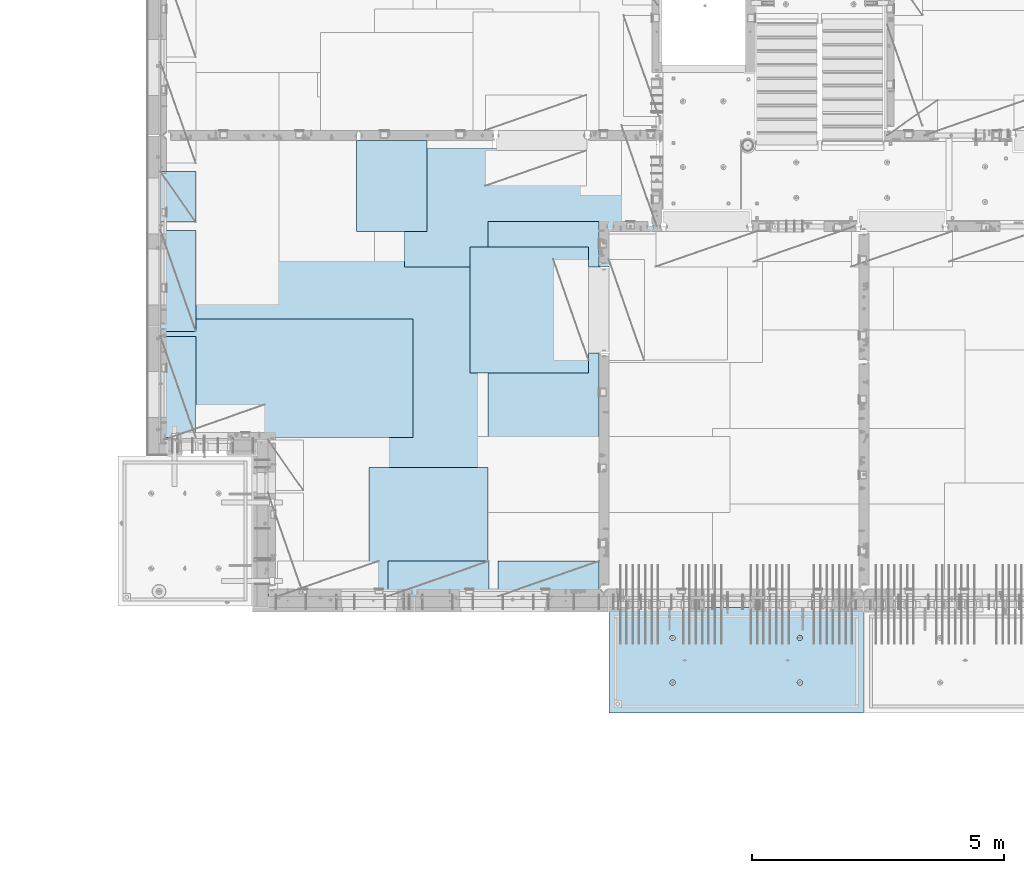
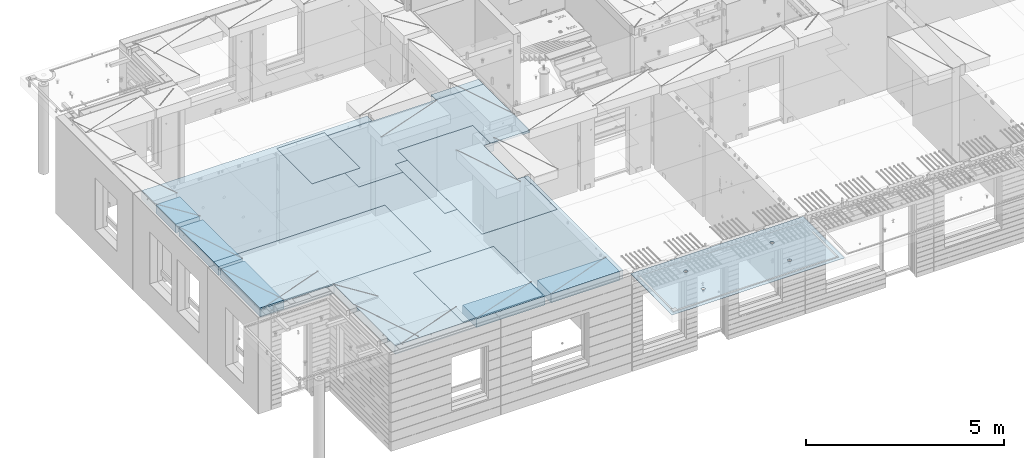
# One storey, part 200 of 349: 11 plates, 2 slabs, 11 elements without a shape of their own.
"""IFC2X3 building model written with IfcOpenShell, lengths in millimetres."""

from ifc_helpers import new_model, si_unit, frame, origin_with_axes, place, context, subcontext, project, spatial, faceted_brep, material, type_object, element, aggregate, save


model = new_model("IFC2X3")

# Units and contexts
model_context = context("Model", 3, precision=1e-05, world=origin_with_axes())
body_context = subcontext(model_context, "Body", "Model", "MODEL_VIEW")
ifc_project = project(units=[si_unit("LENGTHUNIT", "METRE", prefix="MILLI"), si_unit("AREAUNIT", "SQUARE_METRE"), si_unit("VOLUMEUNIT", "CUBIC_METRE"), si_unit("MASSUNIT", "GRAM", prefix="KILO"), si_unit("TIMEUNIT", "SECOND"), si_unit("PLANEANGLEUNIT", "RADIAN"), si_unit("SOLIDANGLEUNIT", "STERADIAN"), si_unit("THERMODYNAMICTEMPERATUREUNIT", "DEGREE_CELSIUS"), si_unit("LUMINOUSINTENSITYUNIT", "LUMEN")], contexts=[model_context])

# Site, building, storey
site_placement = place(None, origin_with_axes())
site = spatial("IfcSite", under=ifc_project, at=site_placement, CompositionType="ELEMENT")
building_placement = place(site_placement, origin_with_axes())
building = spatial("IfcBuilding", under=site, at=building_placement, CompositionType="ELEMENT")
storey_placement = place(building_placement, origin_with_axes())
storey = spatial("IfcBuildingStorey", under=building, at=storey_placement, Name="4", CompositionType="ELEMENT", Elevation=0.0)

# Assembly, slab
assembly_1_placement = place(storey_placement, origin_with_axes())
assembly_1 = element("IfcElementAssembly", 1, at=assembly_1_placement, inside=storey, AssemblyPlace="NOTDEFINED", PredefinedType="REINFORCEMENT_UNIT")
ifc_material_1 = material(Name="CONCRETE/C35/45")
slab_type_1 = type_object("IfcSlabType", PredefinedType="NOTDEFINED")
slab_1_placement = place(assembly_1_placement, frame((21799.9998568133, 7629.99655735226, 93720.0), z_axis=(-1.11800000013248e-06, -0.999999999999375, 0.0), x_axis=(-0.999999999999093, 1.34699999998405e-06, 0.0)))
slab_1 = element("IfcSlab", 2, at=slab_1_placement, type_object=slab_type_1, material=ifc_material_1, PredefinedType="FLOOR", context=body_context, shape_type="Brep", body=[
    faceted_brep([(3730.38290548735, -4.08996566387941, 616.12216176429), (3731.90567362447, 10.0, 615.627386703446), (3739.08833473806, 10.0, 629.724200466487), (3737.80580686752, -3.95055250760925, 630.656008831066), (3750.27560641379, 10.0, 640.911502705889), (3749.35118053074, -3.83997377335618, 642.183862123165), (3764.37240055375, 10.0, 648.094202331947), (3763.88889206625, -3.76900584615942, 649.582281527485), (3779.99882472937, 10.0, 650.569206660445), (3779.99882259584, -3.74455690493051, 652.131088126915), (3795.62525566664, 10.0, 648.094245023346), (3796.1087600739, -3.76900542440126, 649.582325494244), (3809.72206942968, 10.0, 640.911583909758), (3810.64649178305, -3.83997297089081, 642.183945778786), (3820.90937166908, 10.0, 629.724312234022), (3822.19189689232, -3.95055140258046, 630.656124028656), (3828.09207129514, 10.0, 615.627518094066), (3829.61483794004, -4.08996436404414, 616.122297269464), (3830.56707562364, 10.0, 600.001093918447), (3832.18578061358, -4.24460391153116, 600.001096129598), (3828.09211398654, 10.0, 584.374662981175), (3829.64831848373, -4.39934773846471, 583.869023838871), (3820.90945287295, 10.0, 570.277849218135), (3822.24608208202, -4.53903372617788, 569.306734043194), (3809.72218119721, 10.0, 559.090546978732), (3810.70070853473, -4.64994969953841, 557.743723511573), (3795.62538705726, 10.0, 551.907847352675), (3796.14233218844, -4.72119045964791, 550.316861227655), (3779.99896288164, 10.0, 549.432843024176), (3779.99896517058, -4.74574361447594, 547.757190340714), (3764.37253194437, 10.0, 551.907804661275), (3763.85559114489, -4.72119088313775, 550.316817078197), (3750.27571818133, 10.0, 559.090465774863), (3749.29719446955, -4.6499505048414, 557.743639560339), (3739.08841594193, 10.0, 570.277737450599), (3737.75178928409, -4.53903483404429, 569.306618549992), (3731.90571631587, 10.0, 584.374531590555), (3730.34951305942, -4.39934904004622, 583.868888150996), (3729.43071198737, 10.0, 600.000955766174), (3727.81200684201, -4.24460527917836, 600.000953555023), (0.0, 10.0, 0.0), (0.0, -10.0, 0.0), (0.000328360383718973, 10.0, 2085.00366210938), (5040.0, 10.0, -2.18278728425503e-09), (5040.0, -10.0, -2.18278728425503e-09), (5040.00048828125, 10.0, 2085.00366210938), (1210.18496592851, 4.0893025782425, 1468.8123736889), (1210.82376192895, 10.0, 1469.01993205604), (1208.29313952565, 10.0, 1484.99751183111), (1207.63911173254, 4.24455542066426, 1484.99751093771), (1217.61159442581, 3.94915724093153, 1454.20219661341), (1218.16787053537, 10.0, 1454.6063560253), (1229.19498209749, 3.837876675796, 1442.60117732261), (1229.60657282509, 10.0, 1443.16768498606), (1243.80127350603, 3.76640192835475, 1435.14992181469), (1244.02016891989, 10.0, 1435.82361575756), (1259.99775658, 3.74176842256566, 1432.58187432577), (1259.99775560856, 10.0, 1433.29303700502), (1276.19423262309, 3.76640235324157, 1435.14996610939), (1275.97533538363, 10.0, 1435.82365940832), (1290.8005036357, 3.83787748374743, 1442.60126155003), (1290.38891141437, 10.0, 1443.16776801473), (1302.38385956513, 3.94915835243592, 1454.20231248656), (1301.82758245361, 10.0, 1454.60647030446), (1309.81044810845, 4.08930388411682, 1468.81250982317), (1309.17165168211, 10.0, 1469.02006639926), (1312.35625807182, 4.244556792808, 1484.99765398133), (1311.70223043464, 10.0, 1484.99765308793), (1309.77685741928, 4.39970507899125, 1501.17189122433), (1309.17160803135, 10.0, 1500.975232863), (1302.32949611505, 4.53957668620569, 1515.75353188573), (1301.82749942493, 10.0, 1515.38880889374), (1290.74610851982, 4.65051890275208, 1527.31927827547), (1290.3887971352, 10.0, 1526.82747993297), (1276.16055006181, 4.72171992080985, 1534.74199744468), (1275.97520104041, 10.0, 1534.17154916147), (1259.99761353621, 4.74624887190294, 1537.29914508766), (1259.99761435174, 10.0, 1536.70212791401), (1243.83468398195, 4.72171949766926, 1534.74195333328), (1244.02003457667, 10.0, 1534.17150551072), (1229.24914576394, 4.65051809765282, 1527.31919434463), (1229.60645854592, 10.0, 1526.8273969043), (1217.66578971822, 4.53957557752437, 1515.75341630916), (1218.16778750669, 10.0, 1515.38869461457), (1210.21846821205, 4.39970377489226, 1501.17175527336), (1210.82371827819, 10.0, 1500.97509851978), (1210.34950957413, -4.39938207223895, 583.86544460908), (1211.90571640051, 10.0, 584.371089208588), (1209.43071207202, 10.0, 599.997513384207), (1207.81200317426, -4.24463830025343, 599.997511173051), (1217.75178633104, -4.53906787629239, 569.303173961003), (1219.08841602657, 10.0, 570.274295068632), (1229.29719234665, -4.64998355506395, 557.740194139937), (1230.27571826597, 10.0, 559.087023392896), (1243.85559006878, -4.72122393849713, 550.313371123784), (1244.37253202901, 10.0, 551.904362279308), (1259.99896525523, -4.74577667158155, 547.753744202259), (1259.99896296629, 10.0, 549.429400642209), (1276.14233343384, -4.72122351497819, 550.313415273247), (1275.6253871419, 10.0, 551.904404970708), (1290.70071082692, -4.64998274977552, 557.740278091178), (1289.72218128186, 10.0, 559.087104596765), (1302.24608520437, -4.53906676842598, 569.303289454215), (1300.9094529576, 10.0, 570.274406836168), (1309.64832213832, -4.39938077065744, 583.865580296964), (1308.09211407118, 10.0, 584.371220599208), (1312.18578445062, -4.24463693260623, 599.997653747636), (1310.56707570828, 10.0, 599.99765153648), (1309.61484159223, -4.08999737400154, 616.118856046664), (1308.09207137979, 10.0, 615.624075712099), (1302.19190001076, -3.95058440251159, 630.652683850883), (1300.90937175373, 10.0, 629.720869852055), (1290.64649407134, -3.8400059628766, 642.180506429899), (1289.72206951433, 10.0, 640.908141527791), (1276.10876131689, -3.76903841129388, 649.578886677323), (1275.62525575129, 10.0, 648.090802641378), (1259.99882268048, -3.74458989004779, 652.127649493255), (1259.99882481401, 10.0, 650.565764278478), (1243.88889099253, -3.76903883303748, 649.578842710559), (1244.37240063839, 10.0, 648.090759949978), (1229.35117841172, -3.84000676534197, 642.180422774271), (1230.27560649844, 10.0, 640.908060323922), (1217.80580391836, -3.95058550754038, 630.652568653284), (1219.0883348227, 10.0, 629.72075808452), (1210.38290200446, -4.08999867383682, 616.11872054148), (1211.90567370912, 10.0, 615.623944321479), (3795.97520095576, 10.0, 1534.17499154344), (3796.16054881881, 4.72175290768791, 1534.7454362616), (3779.99761345157, 4.74628185702022, 1537.30258372132), (3779.99761426709, 10.0, 1536.70557029598), (3810.38879705055, 10.0, 1526.83092231494), (3810.74610623151, 4.65055189473787, 1527.32271762435), (3821.82749934028, 10.0, 1515.39225127571), (3822.3294929966, 4.53960968612228, 1515.75697206351), (3829.1716079467, 10.0, 1500.97867524496), (3829.7768537671, 4.39973808894865, 1501.17533244712), (3831.70223035, 10.0, 1485.00109546989), (3832.35625423479, 4.24458981388307, 1485.00109636329), (3829.17165159746, 10.0, 1469.02350878122), (3829.81044445387, 4.08933691630955, 1468.81595336508), (3821.82758236896, 10.0, 1454.60991268643), (3822.38385644279, 3.94919139468402, 1454.20575707554), (3810.38891132972, 10.0, 1443.1712103967), (3810.8005013435, 3.83791053396999, 1442.60470697043), (3795.97533529899, 10.0, 1435.82710179029), (3796.19423137769, 3.76643540860096, 1435.1534120638), (3779.99775552391, 10.0, 1433.29647938699), (3779.99775649536, 3.74180147968582, 1432.58532046422), (3764.02016883524, 10.0, 1435.82705813953), (3763.80127458214, 3.76643498368503, 1435.1533677691), (3749.60657274045, 10.0, 1443.17112736803), (3749.19498422039, 3.837909726004, 1442.60462274301), (3738.16787045072, 10.0, 1454.60979840726), (3737.61159737886, 3.94919028317963, 1454.2056412024), (3730.82376184431, 10.0, 1469.023374438), (3730.18496941381, 4.08933561044978, 1468.81581723082), (3737.66579266739, 4.53960857747006, 1515.75685648694), (3749.24914788297, 4.65055108962406, 1527.32263369353), (3763.83468505566, 4.72175248454732, 1534.7453921502), (3727.63911540029, 4.24458844172477, 1485.00095331968), (3730.21847169495, 4.39973678484967, 1501.17519649617), (3764.02003449202, 10.0, 1534.17494789268), (3749.60645846128, 10.0, 1526.83083928627), (3738.16778742204, 10.0, 1515.39213699654), (3730.82371819355, 10.0, 1500.97854090175), (3728.293139441, 10.0, 1485.00095421308)], [[[0, 1, 2, 3]], [[3, 2, 4, 5]], [[5, 4, 6, 7]], [[7, 6, 8, 9]], [[10, 11, 9, 8]], [[12, 13, 11, 10]], [[14, 15, 13, 12]], [[16, 17, 15, 14]], [[18, 19, 17, 16]], [[20, 21, 19, 18]], [[22, 23, 21, 20]], [[24, 25, 23, 22]], [[26, 27, 25, 24]], [[27, 26, 28, 29]], [[29, 28, 30, 31]], [[31, 30, 32, 33]], [[33, 32, 34, 35]], [[35, 34, 36, 37]], [[37, 36, 38, 39]], [[39, 38, 1, 0]], [[40, 41, 42]], [[40, 43, 44, 41]], [[43, 45, 44]], [[46, 47, 48, 49]], [[50, 51, 47, 46]], [[52, 53, 51, 50]], [[54, 55, 53, 52]], [[56, 57, 55, 54]], [[58, 59, 57, 56]], [[60, 61, 59, 58]], [[61, 60, 62, 63]], [[63, 62, 64, 65]], [[65, 64, 66, 67]], [[67, 66, 68, 69]], [[69, 68, 70, 71]], [[71, 70, 72, 73]], [[73, 72, 74, 75]], [[75, 74, 76, 77]], [[77, 76, 78, 79]], [[80, 81, 79, 78]], [[82, 83, 81, 80]], [[84, 85, 83, 82]], [[49, 48, 85, 84]], [[86, 87, 88, 89]], [[90, 91, 87, 86]], [[92, 93, 91, 90]], [[94, 95, 93, 92]], [[96, 97, 95, 94]], [[98, 99, 97, 96]], [[99, 98, 100, 101]], [[101, 100, 102, 103]], [[103, 102, 104, 105]], [[105, 104, 106, 107]], [[107, 106, 108, 109]], [[109, 108, 110, 111]], [[111, 110, 112, 113]], [[113, 112, 114, 115]], [[115, 114, 116, 117]], [[118, 119, 117, 116]], [[120, 121, 119, 118]], [[122, 123, 121, 120]], [[124, 125, 123, 122]], [[89, 88, 125, 124]], [[126, 127, 128, 129]], [[130, 131, 127, 126]], [[132, 133, 131, 130]], [[134, 135, 133, 132]], [[136, 137, 135, 134]], [[138, 139, 137, 136]], [[140, 141, 139, 138]], [[142, 143, 141, 140]], [[143, 142, 144, 145]], [[145, 144, 146, 147]], [[147, 146, 148, 149]], [[149, 148, 150, 151]], [[151, 150, 152, 153]], [[153, 152, 154, 155]], [[41, 44, 45, 42], [3, 5, 7, 9, 11, 13, 15, 17, 19, 21, 23, 25, 27, 29, 31, 33, 35, 37, 39, 0], [156, 157, 158, 128, 127, 131, 133, 135, 137, 139, 141, 143, 145, 147, 149, 151, 153, 155, 159, 160], [122, 120, 118, 116, 114, 112, 110, 108, 106, 104, 102, 100, 98, 96, 94, 92, 90, 86, 89, 124], [82, 80, 78, 76, 74, 72, 70, 68, 66, 64, 62, 60, 58, 56, 54, 52, 50, 46, 49, 84]], [[129, 128, 158, 161]], [[157, 162, 161, 158]], [[156, 163, 162, 157]], [[160, 164, 163, 156]], [[159, 165, 164, 160]], [[155, 154, 165, 159]], [[43, 40, 42, 45], [34, 32, 30, 28, 26, 24, 22, 20, 18, 16, 14, 12, 10, 8, 6, 4, 2, 1, 38, 36], [152, 150, 148, 146, 144, 142, 140, 138, 136, 134, 132, 130, 126, 129, 161, 162, 163, 164, 165, 154], [91, 93, 95, 97, 99, 101, 103, 105, 107, 109, 111, 113, 115, 117, 119, 121, 123, 125, 88, 87], [51, 53, 55, 57, 59, 61, 63, 65, 67, 69, 71, 73, 75, 77, 79, 81, 83, 85, 48, 47]]]),
])
aggregate(assembly_1, [slab_1])

# Assembly, plate
assembly_2_placement = place(storey_placement, origin_with_axes())
assembly_2 = element("IfcElementAssembly", 3, at=assembly_2_placement, inside=storey, Name="Steel Assembly", AssemblyPlace="NOTDEFINED", PredefinedType="NOTDEFINED")
ifc_material_2 = material()
plate_type_1 = type_object("IfcPlateType", PredefinedType="NOTDEFINED")
plate_1_placement = place(assembly_2_placement, frame((14009.7695320312, 12275.0000289158, 93695.1), z_axis=(0.0, 1.0, 0.0), x_axis=(1.0, 0.0, 0.0)))
plate_1 = element("IfcPlate", 4, at=plate_1_placement, type_object=plate_type_1, material=ifc_material_2, Name="1/2", context=body_context, shape_type="Brep", body=[
    faceted_brep([(0.0, -35.0, 0.0), (0.0, -35.0, 2500.0), (0.0, 35.0, 2500.0), (0.0, 35.0, 0.0), (2349.99951171875, -35.0, 2500.0), (2349.99951171875, 35.0, 2500.0), (2350.0, -35.0, 0.0), (2350.0, 35.0, 0.0)], [[[0, 1, 2, 3]], [[1, 4, 5, 2]], [[4, 6, 7, 5]], [[6, 0, 3, 7]], [[5, 7, 3, 2]], [[6, 4, 1, 0]]]),
])
aggregate(assembly_2, [plate_1])

assembly_3_placement = place(storey_placement, origin_with_axes())
assembly_3 = element("IfcElementAssembly", 5, at=assembly_3_placement, inside=storey, Name="Steel Assembly", AssemblyPlace="NOTDEFINED", PredefinedType="NOTDEFINED")
plate_2_placement = place(assembly_3_placement, frame((14360.0, 10400.0, 93695.1), z_axis=(0.0, -1.0, 0.0), x_axis=(-1.0, 3.00000001838171e-08, 0.0)))
plate_2 = element("IfcPlate", 6, at=plate_2_placement, type_object=plate_type_1, material=ifc_material_2, Name="1/2", context=body_context, shape_type="Brep", body=[
    faceted_brep([(0.0, -35.0, 0.0), (0.0, -35.0, 2500.0), (0.0, 35.0, 2500.0), (0.0, 35.0, 0.0), (2349.99951171875, -35.0, 2500.0), (2349.99951171875, 35.0, 2500.0), (2350.0, -35.0, 0.0), (2350.0, 35.0, 0.0)], [[[0, 1, 2, 3]], [[1, 4, 5, 2]], [[4, 6, 7, 5]], [[6, 0, 3, 7]], [[5, 7, 3, 2]], [[6, 4, 1, 0]]]),
])
aggregate(assembly_3, [plate_2])

assembly_4_placement = place(storey_placement, origin_with_axes())
assembly_4 = element("IfcElementAssembly", 7, at=assembly_4_placement, inside=storey, Name="Steel Assembly", AssemblyPlace="NOTDEFINED", PredefinedType="NOTDEFINED")
plate_3_placement = place(assembly_4_placement, frame((12710.0, 16725.0, 93695.1), z_axis=(1.0, 0.0, 0.0), x_axis=(0.0, -1.0, 0.0)))
plate_3 = element("IfcPlate", 8, at=plate_3_placement, type_object=plate_type_1, material=ifc_material_2, context=body_context, shape_type="Brep", body=[
    faceted_brep([(0.0, -35.0, 0.0), (0.0, -35.0, 5000.0), (0.0, 35.0, 5000.0), (0.0, 35.0, 0.0), (2349.99951171875, -35.0, 5000.0), (2349.99951171875, 35.0, 5000.0), (2350.0, -35.0, 0.0), (2350.0, 35.0, 0.0)], [[[0, 1, 2, 3]], [[1, 4, 5, 2]], [[4, 6, 7, 5]], [[6, 0, 3, 7]], [[5, 7, 3, 2]], [[6, 4, 1, 0]]]),
])
aggregate(assembly_4, [plate_3])

assembly_5_placement = place(storey_placement, origin_with_axes())
assembly_5 = element("IfcElementAssembly", 9, at=assembly_5_placement, inside=storey, Name="Steel Assembly", AssemblyPlace="NOTDEFINED", PredefinedType="NOTDEFINED")
plate_4_placement = place(assembly_5_placement, frame((12880.0, 11000.0, 93695.1), z_axis=(-1.0, 3.00000001838171e-08, 0.0), x_axis=(0.0, 1.0, 0.0)))
plate_4 = element("IfcPlate", 10, at=plate_4_placement, type_object=plate_type_1, material=ifc_material_2, context=body_context, shape_type="Brep", body=[
    faceted_brep([(0.0, -35.0, 0.0), (0.0, -35.0, 5000.0), (0.0, 35.0, 5000.0), (0.0, 35.0, 0.0), (2349.99951171875, -35.0, 5000.0), (2349.99951171875, 35.0, 5000.0), (2350.0, -35.0, 0.0), (2350.0, 35.0, 0.0)], [[[0, 1, 2, 3]], [[1, 4, 5, 2]], [[4, 6, 7, 5]], [[6, 0, 3, 7]], [[5, 7, 3, 2]], [[6, 4, 1, 0]]]),
])
aggregate(assembly_5, [plate_4])

assembly_6_placement = place(storey_placement, origin_with_axes())
assembly_6 = element("IfcElementAssembly", 11, at=assembly_6_placement, inside=storey, Name="Steel Assembly", AssemblyPlace="NOTDEFINED", PredefinedType="NOTDEFINED")
plate_type_2 = type_object("IfcPlateType", PredefinedType="NOTDEFINED")
plate_5_placement = place(assembly_6_placement, frame((7879.99987792969, 13000.0, 93595.3), z_axis=(1.0, 0.0, 0.0), x_axis=(0.0, -1.0, 0.0)))
plate_5 = element("IfcPlate", 12, at=plate_5_placement, type_object=plate_type_2, material=ifc_material_2, Name="RE1", context=body_context, shape_type="Brep", body=[
    faceted_brep([(1.81898940354586e-12, -135.0, 1.81898940354586e-12), (0.0, -135.0, 699.999999999996), (0.0, 135.0, 699.999999999996), (1.81898940354586e-12, 135.0, 1.81898940354586e-12), (1999.99951171875, -135.0, 699.999999999993), (1999.99951171875, 135.0, 699.999999999993), (2000.0, -135.0, -3.63797880709171e-12), (2000.0, 135.0, -3.63797880709171e-12)], [[[0, 1, 2, 3]], [[1, 4, 5, 2]], [[4, 6, 7, 5]], [[6, 0, 3, 7]], [[5, 7, 3, 2]], [[6, 4, 1, 0]]]),
])
aggregate(assembly_6, [plate_5])

assembly_7_placement = place(storey_placement, origin_with_axes())
assembly_7 = element("IfcElementAssembly", 13, at=assembly_7_placement, inside=storey, Name="Steel Assembly", AssemblyPlace="NOTDEFINED", PredefinedType="NOTDEFINED")
plate_6_placement = place(assembly_7_placement, frame((7879.99999992931, 16265.0, 93595.3), z_axis=(1.0, 0.0, 0.0), x_axis=(0.0, -1.0, 0.0)))
plate_6 = element("IfcPlate", 14, at=plate_6_placement, type_object=plate_type_2, material=ifc_material_2, Name="RE1_1/2", context=body_context, shape_type="Brep", body=[
    faceted_brep([(1.81898940354586e-12, -135.0, 1.81898940354586e-12), (0.0, -135.0, 699.999999999996), (0.0, 135.0, 699.999999999996), (1.81898940354586e-12, 135.0, 1.81898940354586e-12), (999.99951171875, -135.0, 700.0), (999.99951171875, 135.0, 700.0), (1000.0, -135.0, 0.0), (1000.0, 135.0, 0.0)], [[[0, 1, 2, 3]], [[1, 4, 5, 2]], [[4, 6, 7, 5]], [[6, 0, 3, 7]], [[5, 7, 3, 2]], [[6, 4, 1, 0]]]),
])
aggregate(assembly_7, [plate_6])

assembly_8_placement = place(storey_placement, origin_with_axes())
assembly_8 = element("IfcElementAssembly", 15, at=assembly_8_placement, inside=storey, Name="Steel Assembly", AssemblyPlace="NOTDEFINED", PredefinedType="NOTDEFINED")
plate_7_placement = place(assembly_8_placement, frame((14565.0008542386, 7850.00010363356, 93595.3), z_axis=(0.0, 1.0, 0.0), x_axis=(1.0, 0.0, 0.0)))
plate_7 = element("IfcPlate", 16, at=plate_7_placement, type_object=plate_type_2, material=ifc_material_2, Name="RE1", context=body_context, shape_type="Brep", body=[
    faceted_brep([(1.81898940354586e-12, -135.0, 1.81898940354586e-12), (0.0, -135.0, 699.999999999996), (0.0, 135.0, 699.999999999996), (1.81898940354586e-12, 135.0, 1.81898940354586e-12), (1999.99951171875, -135.0, 699.999999999993), (1999.99951171875, 135.0, 699.999999999993), (2000.0, -135.0, -3.63797880709171e-12), (2000.0, 135.0, -3.63797880709171e-12)], [[[0, 1, 2, 3]], [[1, 4, 5, 2]], [[4, 6, 7, 5]], [[6, 0, 3, 7]], [[5, 7, 3, 2]], [[6, 4, 1, 0]]]),
])
aggregate(assembly_8, [plate_7])

assembly_9_placement = place(storey_placement, origin_with_axes())
assembly_9 = element("IfcElementAssembly", 17, at=assembly_9_placement, inside=storey, Name="Steel Assembly", AssemblyPlace="NOTDEFINED", PredefinedType="NOTDEFINED")
plate_8_placement = place(assembly_9_placement, frame((12382.5008542386, 7850.00010363356, 93595.3), z_axis=(0.0, 1.0, 0.0), x_axis=(1.0, 0.0, 0.0)))
plate_8 = element("IfcPlate", 18, at=plate_8_placement, type_object=plate_type_2, material=ifc_material_2, Name="RE1", context=body_context, shape_type="Brep", body=[
    faceted_brep([(1.81898940354586e-12, -135.0, 1.81898940354586e-12), (0.0, -135.0, 699.999999999996), (0.0, 135.0, 699.999999999996), (1.81898940354586e-12, 135.0, 1.81898940354586e-12), (1999.99951171875, -135.0, 699.999999999993), (1999.99951171875, 135.0, 699.999999999993), (2000.0, -135.0, -3.63797880709171e-12), (2000.0, 135.0, -3.63797880709171e-12)], [[[0, 1, 2, 3]], [[1, 4, 5, 2]], [[4, 6, 7, 5]], [[6, 0, 3, 7]], [[5, 7, 3, 2]], [[6, 4, 1, 0]]]),
])
aggregate(assembly_9, [plate_8])

assembly_10_placement = place(storey_placement, origin_with_axes())
assembly_10 = element("IfcElementAssembly", 19, at=assembly_10_placement, inside=storey, Name="Steel Assembly", AssemblyPlace="NOTDEFINED", PredefinedType="NOTDEFINED")
plate_9_placement = place(assembly_10_placement, frame((7879.99987792969, 15100.0, 93595.3), z_axis=(1.0, 0.0, 0.0), x_axis=(0.0, -1.0, 0.0)))
plate_9 = element("IfcPlate", 20, at=plate_9_placement, type_object=plate_type_2, material=ifc_material_2, Name="RE1", context=body_context, shape_type="Brep", body=[
    faceted_brep([(1.81898940354586e-12, -135.0, 1.81898940354586e-12), (0.0, -135.0, 699.999999999996), (0.0, 135.0, 699.999999999996), (1.81898940354586e-12, 135.0, 1.81898940354586e-12), (1999.99951171875, -135.0, 699.999999999993), (1999.99951171875, 135.0, 699.999999999993), (2000.0, -135.0, -3.63797880709171e-12), (2000.0, 135.0, -3.63797880709171e-12)], [[[0, 1, 2, 3]], [[1, 4, 5, 2]], [[4, 6, 7, 5]], [[6, 0, 3, 7]], [[5, 7, 3, 2]], [[6, 4, 1, 0]]]),
])
aggregate(assembly_10, [plate_9])

# Assembly, plates, slab
assembly_11_placement = place(storey_placement, origin_with_axes())
assembly_11 = element("IfcElementAssembly", 21, at=assembly_11_placement, inside=storey, AssemblyPlace="NOTDEFINED", PredefinedType="REINFORCEMENT_UNIT")
plate_type_3 = type_object("IfcPlateType", PredefinedType="NOTDEFINED")
plate_10_placement = place(assembly_11_placement, frame((13159.9998642727, 15079.9997757405, 93725.45), z_axis=(-1.0, 3.00000001838171e-08, 0.0), x_axis=(0.0, 1.0, 0.0)))
plate_10 = element("IfcPlate", 22, at=plate_10_placement, type_object=plate_type_3, material=ifc_material_2, context=body_context, shape_type="Brep", body=[
    faceted_brep([(0.0, -5.0, 0.0), (0.0, -5.0, 1399.99963378906), (0.0, 5.0, 1399.99963378906), (0.0, 5.0, 0.0), (1800.00024414063, -5.0, 1399.99963378906), (1800.00024414063, 5.0, 1399.99963378906), (1800.00024414063, -5.0, 0.0), (1800.00024414063, 5.0, 0.0)], [[[0, 1, 2, 3]], [[1, 4, 5, 2]], [[4, 6, 7, 5]], [[6, 0, 3, 7]], [[5, 7, 3, 2]], [[6, 4, 1, 0]]]),
])
plate_type_4 = type_object("IfcPlateType", PredefinedType="NOTDEFINED")
plate_11_placement = place(assembly_11_placement, frame((16559.9994828029, 15279.9995850056, 93725.45), z_axis=(0.0, -1.0, 0.0), x_axis=(-1.0, 3.00000001838171e-08, 0.0)))
plate_11 = element("IfcPlate", 23, at=plate_11_placement, type_object=plate_type_4, material=ifc_material_2, context=body_context, shape_type="Brep", body=[
    faceted_brep([(0.0, -5.0, 2604.99950854713), (0.0, 5.0, 2604.99950854713), (200.234115600586, 5.0, 2604.99950854713), (200.234115600586, -5.0, 2604.99950854713), (200.234115600586, 5.0, 904.999508547127), (200.234115600586, -5.0, 904.999508547127), (0.0, -5.0, 904.999508547127), (0.0, 5.0, 904.999508547127), (0.0, -5.0, 4271.99951171875), (2191.99951171875, -5.0, 4271.99951171875), (2191.99951171875, 5.0, 4271.99951171875), (0.0, 5.0, 4271.99951171875), (2191.99951171875, -5.0, 0.0), (2191.99951171875, 5.0, 0.0), (0.0, -5.0, 0.0), (0.0, 5.0, 0.0)], [[[0, 1, 2, 3]], [[3, 2, 4, 5]], [[6, 5, 4, 7]], [[8, 9, 10, 11]], [[9, 12, 13, 10]], [[12, 14, 15, 13]], [[15, 14, 6, 7]], [[2, 1, 11, 10, 13, 15, 7, 4]], [[8, 11, 1, 0]], [[14, 12, 9, 8, 0, 3, 5, 6]]]),
])
ifc_material_3 = material(Name="CONCRETE/C30/37")
slab_type_2 = type_object("IfcSlabType", PredefinedType="NOTDEFINED")
slab_2_placement = place(assembly_11_placement, frame((10010.0, 7850.0, 93595.0), z_axis=(0.0, 1.0, 0.0), x_axis=(1.0, 0.0, 0.0)))
slab_2 = element("IfcSlab", 24, at=slab_2_placement, type_object=slab_type_2, material=ifc_material_3, PredefinedType="FLOOR", context=body_context, shape_type="Brep", body=[
    faceted_brep([(4453.68914550781, -135.0, 9130.0), (-2130.0, -135.0, 9130.0), (-2130.0, -135.0, 3100.0), (0.0, -135.0, 3100.0), (1.81898940354586e-12, -135.0, 1.81898940354586e-12), (6650.0, -135.0, 0.0), (6650.0, -135.0, 4825.00007645847), (6349.76536720235, -135.0, 4825.00007645847), (6349.76536720235, -135.0, 6525.00007645847), (6649.99998634297, -135.0, 6525.00007645847), (6650.0, -135.0, 7330.0), (7700.0, -135.0, 7330.0), (7700.0, -135.0, 9130.0), (6319.99914550781, -135.0, 9130.0), (6319.99914550781, -135.0, 8830.0), (6153.68914550781, -135.0, 8830.0), (4520.0, -135.0, 8830.0), (4453.69, -135.0, 8830.0), (-2130.0, 135.0, 9130.0), (4453.68914550781, 135.0, 9130.0), (-2130.0, 135.0, 3100.0), (0.0, 135.0, 3100.0), (1.81898940354586e-12, 135.0, 1.81898940354586e-12), (6650.0, 135.0, 0.0), (6650.0, 135.0, 4825.00007645847), (6349.76536720235, 135.0, 4825.00007645847), (6349.76536720235, 135.0, 6525.00007645847), (6650.0, 135.0, 6525.00007645847), (6650.0, 135.0, 7330.0), (7700.0, 135.0, 7330.0), (7700.0, 135.0, 9130.0), (6319.99914550781, 135.0, 9130.0), (6319.99914550781, 135.0, 8830.0), (6153.68914550781, 135.0, 8830.0), (4520.0, 135.0, 8830.0), (4453.69, 135.0, 8830.0)], [[[0, 1, 2, 3, 4, 5, 6, 7, 8, 9, 10, 11, 12, 13, 14, 15, 16, 17]], [[18, 1, 0, 19]], [[2, 1, 18, 20]], [[3, 2, 20, 21]], [[4, 3, 21, 22]], [[5, 4, 22, 23]], [[5, 23, 24, 6]], [[6, 24, 25, 7]], [[7, 25, 26, 8]], [[9, 8, 26, 27]], [[28, 10, 9, 27]], [[11, 10, 28, 29]], [[12, 11, 29, 30]], [[12, 30, 31, 13]], [[13, 31, 32, 14]], [[15, 14, 32, 33, 34, 16]], [[16, 34, 35, 17]], [[33, 32, 31, 30, 29, 28, 27, 26, 25, 24, 23, 22, 21, 20, 18, 19, 35, 34]], [[0, 17, 35, 19]]]),
])
aggregate(assembly_11, [plate_10, plate_11, slab_2])

save(model, "model.ifc")
